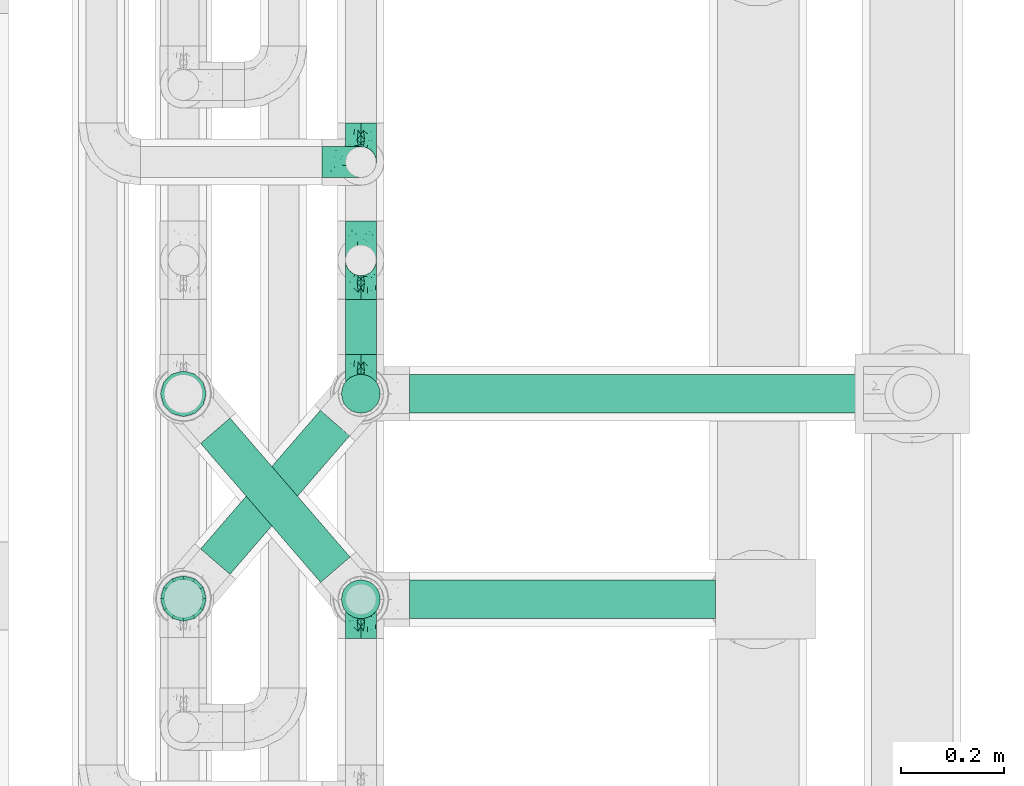
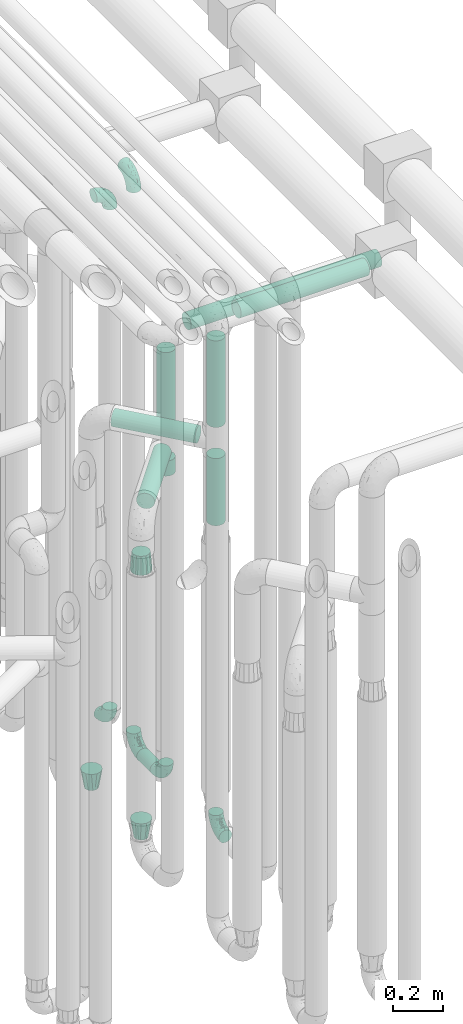
# One storey, part 616 of 824: 9 flow fittings, 9 flow segments.
"""IFC2X3 building model written with IfcOpenShell, lengths in millimetres."""

from ifc_helpers import new_model, entity, si_unit, converted_unit, derived_unit, direction, frame, origin, origin_2d_with_axis, place, context, subcontext, project, spatial, circle, extrude, faceted_brep, source, transform, mapped, material, type_object, type_shapes, element, save


model = new_model("IFC2X3")

# Units and contexts
model_context = context("Model", 3, precision=0.01, world=origin(), true_north=direction((6.12303176911189e-17, 1.0)))
body_context = subcontext(model_context, "Body", "Model", "MODEL_VIEW")
ifc_project = project(units=[si_unit("LENGTHUNIT", "METRE", prefix="MILLI"), si_unit("AREAUNIT", "SQUARE_METRE"), si_unit("VOLUMEUNIT", "CUBIC_METRE"), converted_unit("PLANEANGLEUNIT", "DEGREE", entity("IfcRatioMeasure", 0.0174532925199433), si_unit("PLANEANGLEUNIT", "RADIAN"), dimensions=[0, 0, 0, 0, 0, 0, 0]), si_unit("MASSUNIT", "GRAM", prefix="KILO"), derived_unit("MASSDENSITYUNIT", [(si_unit("MASSUNIT", "GRAM", prefix="KILO"), 1), (si_unit("LENGTHUNIT", "METRE"), -3)]), derived_unit("MOMENTOFINERTIAUNIT", [(si_unit("LENGTHUNIT", "METRE"), 4)]), si_unit("TIMEUNIT", "SECOND"), si_unit("FREQUENCYUNIT", "HERTZ"), si_unit("THERMODYNAMICTEMPERATUREUNIT", "DEGREE_CELSIUS"), derived_unit("THERMALTRANSMITTANCEUNIT", [(si_unit("MASSUNIT", "GRAM", prefix="KILO"), 1), (si_unit("THERMODYNAMICTEMPERATUREUNIT", "KELVIN"), -1), (si_unit("TIMEUNIT", "SECOND"), -3)]), derived_unit("VOLUMETRICFLOWRATEUNIT", [(si_unit("LENGTHUNIT", "METRE"), 3), (si_unit("TIMEUNIT", "SECOND"), -1)]), derived_unit("MASSFLOWRATEUNIT", [(si_unit("MASSUNIT", "GRAM", prefix="KILO"), 1), (si_unit("TIMEUNIT", "SECOND"), -1)]), derived_unit("ROTATIONALFREQUENCYUNIT", [(si_unit("TIMEUNIT", "SECOND"), -1)]), si_unit("ELECTRICCURRENTUNIT", "AMPERE"), si_unit("ELECTRICVOLTAGEUNIT", "VOLT"), si_unit("POWERUNIT", "WATT"), si_unit("FORCEUNIT", "NEWTON", prefix="KILO"), si_unit("ILLUMINANCEUNIT", "LUX"), si_unit("LUMINOUSFLUXUNIT", "LUMEN"), si_unit("LUMINOUSINTENSITYUNIT", "CANDELA"), derived_unit("USERDEFINED", [(si_unit("MASSUNIT", "GRAM", prefix="KILO"), -1), (si_unit("LENGTHUNIT", "METRE"), -2), (si_unit("TIMEUNIT", "SECOND"), 3), (si_unit("LUMINOUSFLUXUNIT", "LUMEN"), 1)]), derived_unit("LINEARVELOCITYUNIT", [(si_unit("LENGTHUNIT", "METRE"), 1), (si_unit("TIMEUNIT", "SECOND"), -1)]), si_unit("PRESSUREUNIT", "PASCAL"), derived_unit("USERDEFINED", [(si_unit("LENGTHUNIT", "METRE"), -2), (si_unit("MASSUNIT", "GRAM", prefix="KILO"), 1), (si_unit("TIMEUNIT", "SECOND"), -2)]), derived_unit("LINEARFORCEUNIT", [(si_unit("MASSUNIT", "GRAM", prefix="KILO"), 1), (si_unit("LENGTHUNIT", "METRE"), 1), (si_unit("TIMEUNIT", "SECOND"), -2), (si_unit("LENGTHUNIT", "METRE"), -1)]), derived_unit("PLANARFORCEUNIT", [(si_unit("MASSUNIT", "GRAM", prefix="KILO"), 1), (si_unit("LENGTHUNIT", "METRE"), 1), (si_unit("TIMEUNIT", "SECOND"), -2), (si_unit("LENGTHUNIT", "METRE"), -2)])], contexts=[model_context])

# Site, building, storey
site_placement = place(None, origin())
site = spatial("IfcSite", under=ifc_project, at=site_placement, CompositionType="ELEMENT")
building_placement = place(site_placement, origin())
building = spatial("IfcBuilding", under=site, at=building_placement, CompositionType="ELEMENT")
storey_placement = place(building_placement, frame((0.0, 0.0, 28200.0)))
storey = spatial("IfcBuildingStorey", under=building, at=storey_placement, CompositionType="ELEMENT", Elevation=28200.0)

# Flow segments
pipe_segment_type = type_object("IfcPipeSegmentType", PredefinedType="NOTDEFINED")
flow_segment_1_placement = place(storey_placement, frame((36943.44, 11806.2, 368.4)))
element("IfcFlowSegment", 1, at=flow_segment_1_placement, inside=storey, type_object=pipe_segment_type, context=body_context, shape_type="SweptSolid", body=[
    extrude(circle(Radius=30.0, at=origin_2d_with_axis()), frame((31.6, 0.0, 31.6), z_axis=(0.0, 1.0, 0.0), x_axis=(-1.0, 0.0, 0.0)), (0.0, 0.0, 1.0), 108.000000000017),
])
flow_segment_2_placement = place(storey_placement, frame((36935.69, 11690.86, 2126.0)))
element("IfcFlowSegment", 2, at=flow_segment_2_placement, inside=storey, type_object=pipe_segment_type, context=body_context, shape_type="SweptSolid", body=[
    extrude(circle(Radius=37.75, at=origin_2d_with_axis()), frame((39.35, 39.35, 0.0), z_axis=(0.0, 0.0, 1.0), x_axis=(-1.0, 0.0, 0.0)), (0.0, 0.0, 1.0), 378.999999999992),
])
flow_segment_3_placement = place(storey_placement, frame((37070.03, 11690.86, 2560.65)))
element("IfcFlowSegment", 3, at=flow_segment_3_placement, inside=storey, type_object=pipe_segment_type, context=body_context, shape_type="SweptSolid", body=[
    extrude(circle(Radius=37.75, at=origin_2d_with_axis()), frame((0.0, 39.35, 39.35), z_axis=(1.0, 0.0, 0.0), x_axis=(0.0, -1.0, 0.0)), (0.0, 0.0, 1.0), 883.26568841584),
])
flow_segment_4_placement = place(storey_placement, frame((36935.69, 11290.86, 2381.0)))
element("IfcFlowSegment", 4, at=flow_segment_4_placement, inside=storey, type_object=pipe_segment_type, context=body_context, shape_type="SweptSolid", body=[
    extrude(circle(Radius=37.75, at=origin_2d_with_axis()), frame((39.35, 39.35, 0.0), z_axis=(-3.6642108849416e-08, 1.69450659784675e-07, 1.0), x_axis=(-1.0, 0.0, -3.66421088494165e-08)), (0.0, 0.0, 1.0), 423.9049607946),
])
flow_segment_5_placement = place(storey_placement, frame((37070.03, 11290.86, 2860.56)))
element("IfcFlowSegment", 5, at=flow_segment_5_placement, inside=storey, type_object=pipe_segment_type, context=body_context, shape_type="SweptSolid", body=[
    extrude(circle(Radius=37.75, at=origin_2d_with_axis()), frame((0.0, 39.35, 39.35), z_axis=(1.0, 0.0, 0.0), x_axis=(0.0, 1.0, 0.0)), (0.0, 0.0, 1.0), 595.765249590932),
])
flow_segment_6_placement = place(storey_placement, frame((36661.57, 11361.47, 2265.65)))
element("IfcFlowSegment", 6, at=flow_segment_6_placement, inside=storey, type_object=pipe_segment_type, context=body_context, shape_type="SweptSolid", body=[
    extrude(circle(Radius=37.75, at=origin_2d_with_axis()), frame((30.17, 296.83, 39.35), z_axis=(0.65359148401651, -0.756847522306242, 0.0), x_axis=(-0.756847522306242, -0.65359148401651, 0.0)), (0.0, 0.0, 1.0), 357.482862990724),
])
flow_segment_7_placement = place(storey_placement, frame((36935.69, 11290.86, 1900.0)))
element("IfcFlowSegment", 7, at=flow_segment_7_placement, inside=storey, type_object=pipe_segment_type, context=body_context, shape_type="SweptSolid", body=[
    extrude(circle(Radius=37.75, at=origin_2d_with_axis()), frame((39.35, 39.35, 0.0), z_axis=(0.0, 0.0, 1.0), x_axis=(-1.0, 0.0, 0.0)), (0.0, 0.0, 1.0), 328.999999999994),
])
flow_segment_8_placement = place(storey_placement, frame((36661.57, 11377.22, 2010.65)))
element("IfcFlowSegment", 8, at=flow_segment_8_placement, inside=storey, type_object=pipe_segment_type, context=body_context, shape_type="SweptSolid", body=[
    extrude(circle(Radius=37.75, at=origin_2d_with_axis()), frame((30.17, 26.27, 39.35), z_axis=(0.653617255256319, 0.756825266247894, 0.0), x_axis=(0.756825266247894, -0.653617255256319, 0.0)), (0.0, 0.0, 1.0), 356.436515701913),
])
flow_segment_9_placement = place(storey_placement, frame((36935.69, 11690.86, 1900.0)))
element("IfcFlowSegment", 9, at=flow_segment_9_placement, inside=storey, type_object=pipe_segment_type, context=body_context, shape_type="SweptSolid", body=[
    extrude(circle(Radius=37.75, at=origin_2d_with_axis()), frame((39.35, 39.35, 0.0), z_axis=(0.0, 0.0, 1.0), x_axis=(-1.0, 0.0, 0.0)), (0.0, 0.0, 1.0), 74.0000000000048),
])

# Flow fittings
ifc_material = material()
pipe_fitting_type_1 = type_object("IfcPipeFittingType", PredefinedType="NOTDEFINED", material=ifc_material)
shared_shape_1 = source(origin(), body_context, "Body", "Brep", [
    faceted_brep([(-76.0, 15.07, -26.11), (-76.0, 7.8, -29.12), (-76.0, 0.0, -30.15), (-76.0, -7.8, -29.12), (-76.0, -15.08, -26.11), (-76.0, -21.32, -21.32), (-76.0, -26.11, -15.08), (-76.0, -29.12, -7.8), (-76.0, -30.15, 0.0), (-76.0, -29.12, 7.8), (-76.0, -26.11, 15.07), (-76.0, -21.32, 21.32), (-76.0, -15.08, 26.11), (-76.0, -7.8, 29.12), (-76.0, 0.0, 30.15), (-76.0, 7.8, 29.12), (-76.0, 15.07, 26.11), (-76.0, 21.32, 21.32), (-76.0, 26.11, 15.07), (-76.0, 29.12, 7.8), (-76.0, 30.15, 0.0), (-76.0, 29.12, -7.8), (-76.0, 26.11, -15.08), (-76.0, 21.32, -21.32), (0.0, 76.0, -30.15), (-7.8, 76.0, -29.12), (-15.07, 76.0, -26.11), (-21.32, 76.0, -21.32), (-26.11, 76.0, -15.08), (-29.12, 76.0, -7.8), (-30.15, 76.0, 0.0), (-29.12, 76.0, 7.8), (-26.11, 76.0, 15.07), (-21.32, 76.0, 21.32), (-15.07, 76.0, 26.11), (-7.8, 76.0, 29.12), (0.0, 76.0, 30.15), (7.8, 76.0, 29.12), (15.08, 76.0, 26.11), (21.32, 76.0, 21.32), (26.11, 76.0, 15.07), (29.12, 76.0, 7.8), (30.15, 76.0, 0.0), (29.12, 76.0, -7.8), (26.11, 76.0, -15.08), (21.32, 76.0, -21.32), (15.08, 76.0, -26.11), (7.8, 76.0, -29.12), (10.79, 31.43, 21.07), (4.32, 31.7, 25.72), (1.65, 15.19, 19.92), (-61.17, -27.8, 0.0), (-51.1, -25.49, 9.84), (-56.14, -10.61, 27.27), (-31.7, -4.32, 25.72), (-39.75, 1.72, 29.41), (-43.2, -24.95, 0.0), (-1.86, 1.86, 0.0), (4.49, 7.65, 5.78), (-7.82, -4.61, 5.83), (-56.21, -22.79, 17.21), (-58.98, -3.38, 29.7), (-53.96, 5.6, 30.07), (-10.86, 10.86, 25.48), (-17.2, -2.6, 20.44), (-49.15, -16.01, 22.7), (-22.18, -14.24, 7.99), (-28.4, -17.42, 0.0), (-13.61, -9.88, 0.0), (-39.0, 23.48, 27.76), (-58.76, 12.54, 28.36), (-41.61, 15.41, 29.48), (16.01, 49.15, 22.7), (-58.55, 25.93, 19.53), (-51.53, 33.5, 13.51), (-64.92, 28.76, 12.4), (-7.48, 23.14, 28.25), (-1.72, 39.75, 29.41), (-12.04, 27.88, 29.88), (-63.91, 18.81, 24.52), (-11.63, 65.16, 28.18), (-4.97, 57.02, 30.05), (9.88, 13.61, 0.0), (-62.5, 31.74, 5.02), (-45.17, 30.98, 21.2), (-21.78, 9.76, 28.58), (10.61, 56.14, 27.27), (-32.09, 54.42, 13.26), (22.79, 56.21, 17.21), (15.38, 31.17, 15.63), (25.49, 51.1, 9.84), (21.84, 36.35, 5.92), (24.95, 43.2, 0.0), (3.38, 58.98, 29.7), (-31.17, -15.38, 15.63), (-39.39, 41.78, 15.45), (-34.56, 41.13, 20.79), (-39.81, -23.25, 5.49), (27.8, 61.17, 0.0), (-31.74, 62.5, 5.02), (-53.07, 36.29, 0.0), (-42.95, 42.95, 7.29), (-36.29, 53.07, 0.0), (-19.83, 58.51, 24.79), (-25.48, 60.2, 19.41), (-14.53, 50.96, 28.57), (-13.31, 37.09, 30.07), (-26.16, 40.06, 26.4), (-32.43, -10.35, 21.9), (17.42, 28.4, 0.0), (14.24, 22.18, 7.99), (-38.67, 9.72, 30.15), (-24.66, 17.36, 30.09), (-37.08, 31.49, 24.99), (-49.27, 22.83, 25.24), (-20.8, 38.81, 28.63), (-27.58, 27.58, 29.2), (-36.07, -20.23, 10.71), (-15.19, -6.16, 14.9), (6.6, 15.4, 14.49), (-2.51, 2.51, 11.35), (-65.16, 11.63, -28.18), (-49.15, -16.01, -22.7), (-57.02, 4.97, -30.05), (-25.93, 58.55, -19.53), (-33.5, 51.53, -13.51), (-28.76, 64.92, -12.4), (-60.2, 25.48, -19.41), (-58.51, 19.83, -24.79), (4.61, 7.82, -5.83), (-7.65, -4.49, -5.78), (-2.51, 2.51, -11.35), (-62.5, 31.74, -5.02), (-50.96, 14.53, -28.57), (-37.09, 13.31, -30.07), (-42.95, 42.95, -7.29), (25.49, 51.1, -9.84), (22.79, 56.21, -17.21), (-40.06, 26.16, -26.4), (3.38, 58.98, -29.7), (-5.6, 53.96, -30.07), (-27.88, 12.04, -29.88), (-9.76, 21.78, -28.58), (-23.14, 7.48, -28.25), (-51.1, -25.49, -9.84), (15.38, 31.17, -15.63), (16.01, 49.15, -22.7), (-23.48, 39.0, -27.76), (-12.54, 58.76, -28.36), (-15.41, 41.61, -29.48), (-56.21, -22.79, -17.21), (-9.72, 38.67, -30.15), (-17.36, 24.66, -30.09), (-22.18, -14.24, -7.99), (-41.13, 34.56, -20.79), (-31.74, 62.5, -5.02), (-58.98, -3.38, -29.7), (-31.17, -15.38, -15.63), (-56.14, -10.61, -27.27), (14.24, 22.18, -7.99), (23.25, 39.81, -5.49), (-31.49, 37.08, -24.99), (-15.19, -6.16, -14.9), (1.65, 15.19, -19.92), (-18.81, 63.91, -24.52), (-32.59, -11.62, -20.84), (-31.7, -4.32, -25.72), (-17.2, -2.6, -20.44), (-39.75, 1.72, -29.41), (-54.42, 32.09, -13.26), (-30.98, 45.17, -21.2), (10.61, 56.14, -27.27), (10.23, 31.31, -21.52), (4.32, 31.7, -25.72), (-41.78, 39.39, -15.45), (-1.72, 39.75, -29.41), (-36.35, -21.84, -5.92), (-22.83, 49.27, -25.24), (-38.81, 20.8, -28.63), (-27.58, 27.58, -29.2), (-10.86, 10.86, -25.48), (20.23, 36.07, -10.71), (6.6, 15.4, -14.49)], [[[0, 1, 2, 3, 4, 5, 6, 7, 8, 9, 10, 11, 12, 13, 14, 15, 16, 17, 18, 19, 20, 21, 22, 23]], [[24, 25, 26, 27, 28, 29, 30, 31, 32, 33, 34, 35, 36, 37, 38, 39, 40, 41, 42, 43, 44, 45, 46, 47]], [[48, 49, 50]], [[51, 52, 9]], [[53, 54, 55]], [[9, 52, 10]], [[56, 52, 51]], [[57, 58, 59]], [[11, 10, 60]], [[14, 61, 62]], [[63, 54, 64]], [[65, 12, 11]], [[65, 53, 12]], [[66, 67, 68]], [[69, 70, 71]], [[72, 39, 38]], [[73, 74, 75]], [[15, 70, 16]], [[76, 77, 78]], [[16, 79, 17]], [[13, 61, 14]], [[35, 80, 81]], [[14, 62, 15]], [[17, 73, 18]], [[57, 82, 58]], [[20, 19, 83]], [[75, 19, 18]], [[70, 15, 62]], [[73, 84, 74]], [[78, 85, 76]], [[38, 86, 72]], [[32, 31, 87]], [[88, 89, 90]], [[91, 92, 90]], [[72, 86, 49]], [[36, 93, 37]], [[75, 83, 19]], [[36, 35, 81]], [[60, 94, 65]], [[40, 90, 41]], [[95, 96, 87]], [[88, 90, 40]], [[66, 97, 67]], [[90, 98, 41]], [[40, 39, 88]], [[99, 31, 30]], [[20, 83, 100]], [[101, 102, 100]], [[52, 60, 10]], [[102, 99, 30]], [[96, 103, 104]], [[83, 101, 100]], [[12, 53, 13]], [[104, 103, 33]], [[105, 106, 81]], [[107, 105, 103]], [[64, 54, 108]], [[80, 103, 105]], [[80, 35, 34]], [[34, 33, 103]], [[86, 38, 37]], [[109, 110, 82]], [[71, 111, 112]], [[69, 107, 113]], [[79, 73, 17]], [[114, 113, 84]], [[33, 32, 104]], [[115, 107, 116]], [[105, 115, 106]], [[93, 81, 77]], [[54, 53, 65]], [[61, 53, 55]], [[108, 94, 64]], [[54, 63, 85]], [[93, 86, 37]], [[77, 76, 49]], [[77, 49, 86]], [[49, 63, 50]], [[60, 52, 117]], [[65, 11, 60]], [[39, 72, 88]], [[89, 88, 72]], [[71, 70, 62]], [[79, 70, 114]], [[103, 96, 107]], [[69, 113, 114]], [[112, 106, 116]], [[77, 81, 106]], [[112, 116, 71]], [[112, 55, 85]], [[64, 50, 63]], [[57, 59, 68]], [[32, 87, 104]], [[96, 104, 87]], [[94, 118, 64]], [[50, 119, 89]], [[50, 64, 118]], [[50, 89, 48]], [[81, 93, 36]], [[86, 93, 77]], [[53, 61, 13]], [[62, 61, 55]], [[71, 62, 111]], [[69, 71, 116]], [[95, 101, 74]], [[99, 101, 87]], [[118, 66, 59]], [[117, 97, 66]], [[117, 66, 94]], [[91, 89, 110]], [[91, 110, 109]], [[110, 89, 119]], [[9, 8, 51]], [[98, 90, 92]], [[98, 42, 41]], [[101, 83, 74]], [[101, 99, 102]], [[87, 31, 99]], [[62, 55, 111]], [[55, 112, 111]], [[107, 69, 116]], [[70, 69, 114]], [[107, 96, 113]], [[84, 113, 96]], [[84, 96, 95]], [[114, 84, 73]], [[70, 79, 16]], [[73, 79, 114]], [[54, 85, 55]], [[76, 85, 63]], [[49, 76, 63]], [[77, 106, 78]], [[106, 112, 78]], [[85, 78, 112]], [[73, 75, 18]], [[83, 75, 74]], [[103, 80, 34]], [[81, 80, 105]], [[101, 95, 87]], [[84, 95, 74]], [[106, 115, 116]], [[105, 107, 115]], [[120, 59, 58]], [[82, 110, 58]], [[119, 58, 110]], [[118, 59, 120]], [[66, 68, 59]], [[54, 65, 108]], [[94, 108, 65]], [[66, 118, 94]], [[50, 118, 120]], [[50, 120, 119]], [[119, 120, 58]], [[89, 72, 48]], [[49, 48, 72]], [[60, 117, 94]], [[117, 52, 97]], [[52, 56, 97]], [[67, 97, 56]], [[92, 91, 109]], [[89, 91, 90]], [[121, 1, 0]], [[122, 5, 4]], [[2, 1, 123]], [[124, 125, 126]], [[127, 128, 23]], [[129, 130, 131]], [[100, 132, 20]], [[133, 134, 123]], [[135, 100, 102]], [[136, 137, 44]], [[133, 128, 138]], [[24, 139, 140]], [[141, 142, 143]], [[121, 128, 133]], [[6, 144, 7]], [[137, 145, 146]], [[144, 51, 7]], [[147, 148, 149]], [[144, 6, 150]], [[149, 151, 152]], [[153, 68, 67]], [[154, 128, 127]], [[30, 155, 102]], [[43, 42, 98]], [[156, 3, 2]], [[157, 144, 150]], [[158, 4, 3]], [[24, 140, 25]], [[155, 135, 102]], [[159, 160, 109]], [[30, 29, 155]], [[147, 138, 161]], [[27, 124, 28]], [[57, 129, 82]], [[162, 163, 131]], [[27, 26, 164]], [[148, 26, 25]], [[165, 166, 167]], [[24, 47, 139]], [[143, 168, 141]], [[22, 21, 169]], [[125, 124, 170]], [[148, 25, 140]], [[46, 146, 171]], [[158, 122, 4]], [[0, 23, 128]], [[1, 121, 123]], [[109, 82, 159]], [[45, 44, 137]], [[146, 46, 45]], [[136, 43, 98]], [[132, 21, 20]], [[136, 98, 92]], [[172, 173, 146]], [[46, 171, 47]], [[43, 136, 44]], [[174, 154, 169]], [[171, 173, 175]], [[6, 5, 150]], [[126, 29, 28]], [[176, 56, 144]], [[122, 158, 166]], [[164, 124, 27]], [[177, 161, 170]], [[23, 22, 127]], [[178, 138, 179]], [[133, 178, 134]], [[156, 123, 168]], [[156, 158, 3]], [[168, 143, 166]], [[168, 166, 158]], [[166, 180, 167]], [[173, 171, 146]], [[139, 171, 175]], [[172, 145, 163]], [[173, 180, 142]], [[5, 122, 150]], [[157, 150, 122]], [[137, 136, 181]], [[146, 45, 137]], [[149, 148, 140]], [[164, 148, 177]], [[128, 154, 138]], [[147, 161, 177]], [[152, 134, 179]], [[168, 123, 134]], [[152, 179, 149]], [[152, 175, 142]], [[57, 130, 129]], [[157, 165, 167]], [[22, 169, 127]], [[154, 127, 169]], [[163, 167, 180]], [[162, 157, 167]], [[173, 163, 180]], [[182, 163, 145]], [[123, 156, 2]], [[158, 156, 168]], [[171, 139, 47]], [[140, 139, 175]], [[149, 140, 151]], [[147, 149, 179]], [[174, 135, 125]], [[132, 135, 169]], [[176, 157, 153]], [[176, 153, 67]], [[153, 157, 162]], [[182, 159, 129]], [[181, 160, 159]], [[181, 159, 145]], [[51, 144, 56]], [[51, 8, 7]], [[135, 132, 100]], [[169, 21, 132]], [[126, 155, 29]], [[135, 155, 125]], [[140, 175, 151]], [[175, 152, 151]], [[138, 147, 179]], [[148, 147, 177]], [[138, 154, 161]], [[170, 161, 154]], [[170, 154, 174]], [[177, 170, 124]], [[148, 164, 26]], [[124, 164, 177]], [[173, 142, 175]], [[143, 142, 180]], [[166, 143, 180]], [[168, 134, 141]], [[134, 152, 141]], [[142, 141, 152]], [[124, 126, 28]], [[155, 126, 125]], [[128, 121, 0]], [[123, 121, 133]], [[135, 174, 169]], [[170, 174, 125]], [[134, 178, 179]], [[133, 138, 178]], [[130, 153, 162]], [[68, 153, 130]], [[57, 68, 130]], [[182, 129, 131]], [[159, 82, 129]], [[157, 122, 165]], [[166, 165, 122]], [[163, 162, 167]], [[162, 131, 130]], [[145, 172, 146]], [[163, 173, 172]], [[159, 182, 145]], [[131, 163, 182]], [[56, 176, 67]], [[157, 176, 144]], [[137, 181, 145]], [[181, 136, 160]], [[136, 92, 160]], [[109, 160, 92]]]),
])
type_shapes(pipe_fitting_type_1, [shared_shape_1])
for number, where, z_axis, x_axis in (
    (10, (36975.03, 12181.17, 3000.0), (0.0, 1.0, 0.0), (1.0, 0.0, 0.0)),
    (11, (36975.03, 12181.17, 400.0), (1.0, 0.0, 0.0), (0.0, 0.0, -1.0)),
    (12, (36975.03, 11330.2, 400.0), (1.0, 0.0, 0.0), (0.0, 1.0, 0.0)),
    (13, (36975.03, 11730.2, 400.0), (-1.0, 0.0, 0.0), (0.0, -1.0, 0.0)),
    (14, (36975.03, 11990.2, 3200.0), (1.0, 0.0, 0.0), (0.0, -1.0, 0.0)),
    (15, (36975.03, 11990.2, 400.0), (1.0, 0.0, 0.0), (0.0, 1.0, 0.0)),
):
    element("IfcFlowFitting", number, at=place(storey_placement, frame(where, z_axis=z_axis, x_axis=x_axis)), inside=storey, type_object=pipe_fitting_type_1, material=ifc_material, context=body_context, shape_type="MappedRepresentation", body=[
        mapped(shared_shape_1, transform((0.0, 0.0, 0.0), scale=1.0)),
    ])
pipe_fitting_type_2 = type_object("IfcPipeFittingType", PredefinedType="NOTDEFINED", material=ifc_material)
shared_shape_2 = source(origin(), body_context, "Body", "Brep", [
    faceted_brep([(89.0, -44.45, 0.0), (89.0, -41.96, -9.31), (89.0, -38.49, -22.22), (89.0, -30.36, -30.36), (89.0, -22.23, -38.49), (89.0, -11.11, -41.47), (89.0, 0.0, -44.45), (89.0, 11.11, -41.47), (89.0, 22.22, -38.49), (89.0, 30.36, -30.36), (89.0, 38.49, -22.22), (89.0, 41.96, -9.31), (89.0, 44.45, 0.0), (89.0, 41.96, 9.31), (89.0, 38.49, 22.23), (89.0, 30.36, 30.36), (89.0, 22.22, 38.49), (89.0, 11.11, 41.47), (89.0, 0.0, 44.45), (89.0, -11.11, 41.47), (89.0, -22.23, 38.49), (89.0, -30.36, 30.36), (89.0, -38.49, 22.23), (89.0, -41.96, 9.31), (0.0, 38.05, 0.0), (0.0, 35.5, -9.51), (0.0, 32.95, -19.02), (0.0, 25.99, -25.99), (0.0, 19.02, -32.95), (0.0, 9.51, -35.5), (0.0, 0.0, -38.05), (0.0, -9.51, -35.5), (0.0, -19.03, -32.95), (0.0, -25.99, -25.99), (0.0, -32.95, -19.02), (0.0, -35.5, -9.51), (0.0, -38.05, 0.0), (0.0, -35.5, 9.51), (0.0, -32.95, 19.03), (0.0, -25.99, 25.99), (0.0, -19.03, 32.95), (0.0, -9.51, 35.5), (0.0, 0.0, 38.05), (0.0, 9.51, 35.5), (0.0, 19.03, 32.95), (0.0, 25.99, 25.99), (0.0, 32.95, 19.03), (0.0, 35.5, 9.51)], [[[0, 1, 2, 3, 4, 5, 6, 7, 8, 9, 10, 11, 12, 13, 14, 15, 16, 17, 18, 19, 20, 21, 22, 23]], [[24, 25, 26, 27, 28, 29, 30, 31, 32, 33, 34, 35, 36, 37, 38, 39, 40, 41, 42, 43, 44, 45, 46, 47]], [[2, 1, 0, 36, 35, 34]], [[28, 8, 7, 6, 30, 29]], [[32, 4, 3, 2, 34, 33]], [[5, 4, 32, 31, 30, 6]], [[10, 26, 25, 24, 12, 11]], [[9, 8, 28, 27, 26, 10]], [[14, 13, 12, 24, 47, 46]], [[40, 20, 19, 18, 42, 41]], [[44, 16, 15, 14, 46, 45]], [[17, 16, 44, 43, 42, 18]], [[22, 38, 37, 36, 0, 23]], [[21, 20, 40, 39, 38, 22]]]),
])
type_shapes(pipe_fitting_type_2, [shared_shape_2])
flow_fitting_1_placement = place(storey_placement, frame((36629.64, 11331.59, 1870.0), z_axis=(0.0, 1.0, 0.0), x_axis=(0.0, 0.0, -1.0)))
element("IfcFlowFitting", 16, at=flow_fitting_1_placement, inside=storey, type_object=pipe_fitting_type_2, material=ifc_material, context=body_context, shape_type="MappedRepresentation", body=[
    mapped(shared_shape_2, transform((0.0, 0.0, 0.0), scale=1.0)),
])
pipe_fitting_type_3 = type_object("IfcPipeFittingType", PredefinedType="NOTDEFINED", material=ifc_material)
shared_shape_3 = source(origin(), body_context, "Body", "Brep", [
    faceted_brep([(89.0, -44.45, 0.0), (89.0, -42.1, -8.76), (89.0, -38.49, -22.22), (89.0, -30.36, -30.36), (89.0, -22.23, -38.49), (89.0, -11.11, -41.47), (89.0, 0.0, -44.45), (89.0, 11.11, -41.47), (89.0, 22.22, -38.49), (89.0, 30.36, -30.36), (89.0, 38.49, -22.22), (89.0, 42.1, -8.76), (89.0, 44.45, 0.0), (89.0, 42.1, 8.76), (89.0, 38.49, 22.23), (89.0, 30.36, 30.36), (89.0, 22.22, 38.49), (89.0, 11.11, 41.47), (89.0, 0.0, 44.45), (89.0, -11.11, 41.47), (89.0, -22.23, 38.49), (89.0, -30.36, 30.36), (89.0, -38.49, 22.23), (89.0, -42.1, 8.76), (0.0, 30.15, 0.0), (0.0, 27.27, -8.86), (0.0, 24.39, -17.72), (0.0, 16.85, -23.2), (0.0, 9.32, -28.67), (0.0, 0.0, -28.67), (0.0, -9.32, -28.67), (0.0, -16.85, -23.2), (0.0, -24.39, -17.72), (0.0, -27.27, -8.86), (0.0, -30.15, 0.0), (0.0, -27.27, 8.86), (0.0, -24.39, 17.72), (0.0, -16.85, 23.2), (0.0, -9.32, 28.67), (0.0, 0.0, 28.67), (0.0, 9.32, 28.67), (0.0, 16.85, 23.2), (0.0, 24.39, 17.72), (0.0, 27.27, 8.86)], [[[0, 1, 2, 3, 4, 5, 6, 7, 8, 9, 10, 11, 12, 13, 14, 15, 16, 17, 18, 19, 20, 21, 22, 23]], [[24, 25, 26, 27, 28, 29, 30, 31, 32, 33, 34, 35, 36, 37, 38, 39, 40, 41, 42, 43]], [[2, 33, 32]], [[28, 7, 29]], [[29, 5, 30]], [[24, 12, 11]], [[3, 32, 31]], [[34, 1, 0]], [[1, 34, 33]], [[8, 28, 27]], [[2, 1, 33]], [[31, 4, 3]], [[2, 32, 3]], [[11, 25, 24]], [[26, 10, 9]], [[10, 25, 11]], [[28, 8, 7]], [[27, 26, 9]], [[26, 25, 10]], [[31, 30, 4]], [[8, 27, 9]], [[29, 7, 6]], [[5, 29, 6]], [[5, 4, 30]], [[14, 43, 42]], [[38, 19, 39]], [[39, 17, 40]], [[34, 0, 23]], [[15, 42, 41]], [[24, 13, 12]], [[13, 24, 43]], [[20, 38, 37]], [[14, 13, 43]], [[41, 16, 15]], [[14, 42, 15]], [[23, 35, 34]], [[36, 22, 21]], [[22, 35, 23]], [[38, 20, 19]], [[37, 36, 21]], [[36, 35, 22]], [[41, 40, 16]], [[20, 37, 21]], [[39, 19, 18]], [[17, 39, 18]], [[17, 16, 40]]]),
])
type_shapes(pipe_fitting_type_3, [shared_shape_3])
flow_fitting_2_placement = place(storey_placement, frame((36629.64, 11331.59, 476.0), z_axis=(1.0, 0.0, 0.0), x_axis=(0.0, 0.0, 1.0)))
element("IfcFlowFitting", 17, at=flow_fitting_2_placement, inside=storey, type_object=pipe_fitting_type_3, material=ifc_material, context=body_context, shape_type="MappedRepresentation", body=[
    mapped(shared_shape_3, transform((0.0, 0.0, 0.0), scale=1.0)),
])
pipe_fitting_type_4 = type_object("IfcPipeFittingType", PredefinedType="NOTDEFINED", material=ifc_material)
shared_shape_4 = source(origin(), body_context, "Body", "Brep", [
    faceted_brep([(89.0, 38.49, -22.22), (89.0, 42.1, -8.76), (89.0, 44.45, 0.0), (89.0, 42.1, 8.76), (89.0, 38.49, 22.23), (89.0, 30.36, 30.36), (89.0, 22.23, 38.49), (89.0, 11.11, 41.47), (89.0, 0.0, 44.45), (89.0, -11.11, 41.47), (89.0, -22.22, 38.49), (89.0, -30.36, 30.36), (89.0, -38.49, 22.23), (89.0, -42.1, 8.76), (89.0, -44.45, 0.0), (89.0, -42.1, -8.76), (89.0, -38.49, -22.22), (89.0, -30.36, -30.36), (89.0, -22.22, -38.49), (89.0, -11.11, -41.47), (89.0, 0.0, -44.45), (89.0, 11.11, -41.47), (89.0, 22.23, -38.49), (89.0, 30.36, -30.36), (0.0, -24.39, -17.72), (0.0, -27.27, -8.86), (0.0, -30.15, 0.0), (0.0, -27.27, 8.86), (0.0, -24.39, 17.72), (0.0, -16.85, 23.2), (0.0, -9.32, 28.67), (0.0, 0.0, 28.67), (0.0, 9.32, 28.67), (0.0, 16.85, 23.2), (0.0, 24.39, 17.72), (0.0, 27.27, 8.86), (0.0, 30.15, 0.0), (0.0, 27.27, -8.86), (0.0, 24.39, -17.72), (0.0, 16.85, -23.2), (0.0, 9.32, -28.67), (0.0, 0.0, -28.67), (0.0, -9.32, -28.67), (0.0, -16.85, -23.2)], [[[0, 1, 2, 3, 4, 5, 6, 7, 8, 9, 10, 11, 12, 13, 14, 15, 16, 17, 18, 19, 20, 21, 22, 23]], [[24, 25, 26, 27, 28, 29, 30, 31, 32, 33, 34, 35, 36, 37, 38, 39, 40, 41, 42, 43]], [[38, 37, 0]], [[41, 19, 42]], [[40, 21, 41]], [[15, 14, 26]], [[39, 38, 23]], [[2, 1, 36]], [[37, 36, 1]], [[43, 42, 18]], [[37, 1, 0]], [[23, 22, 39]], [[23, 38, 0]], [[26, 25, 15]], [[17, 16, 24]], [[15, 25, 16]], [[19, 18, 42]], [[17, 24, 43]], [[16, 25, 24]], [[22, 40, 39]], [[17, 43, 18]], [[20, 19, 41]], [[20, 41, 21]], [[40, 22, 21]], [[28, 27, 12]], [[31, 7, 32]], [[30, 9, 31]], [[3, 2, 36]], [[29, 28, 11]], [[14, 13, 26]], [[27, 26, 13]], [[33, 32, 6]], [[27, 13, 12]], [[11, 10, 29]], [[11, 28, 12]], [[36, 35, 3]], [[5, 4, 34]], [[3, 35, 4]], [[7, 6, 32]], [[5, 34, 33]], [[4, 35, 34]], [[10, 30, 29]], [[5, 33, 6]], [[8, 7, 31]], [[8, 31, 9]], [[30, 10, 9]]]),
])
type_shapes(pipe_fitting_type_4, [shared_shape_4])
flow_fitting_3_placement = place(storey_placement, frame((36629.64, 11730.2, 476.0), z_axis=(0.0, 1.0, 0.0), x_axis=(0.0, 0.0, 1.0)))
element("IfcFlowFitting", 18, at=flow_fitting_3_placement, inside=storey, type_object=pipe_fitting_type_4, material=ifc_material, context=body_context, shape_type="MappedRepresentation", body=[
    mapped(shared_shape_4, transform((0.0, 0.0, 0.0), scale=1.0)),
])

save(model, "model.ifc")
